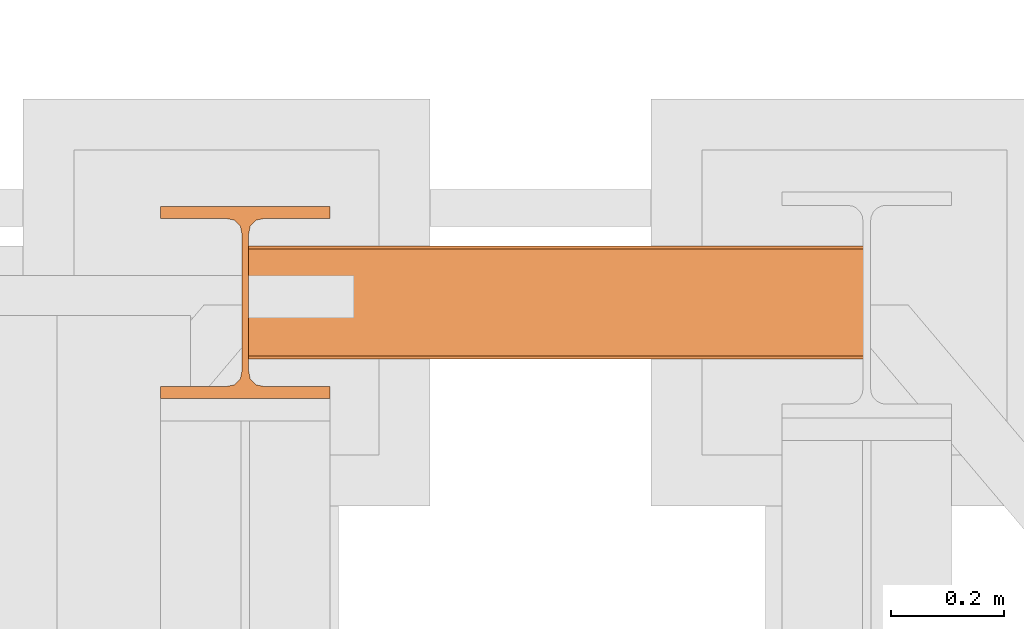
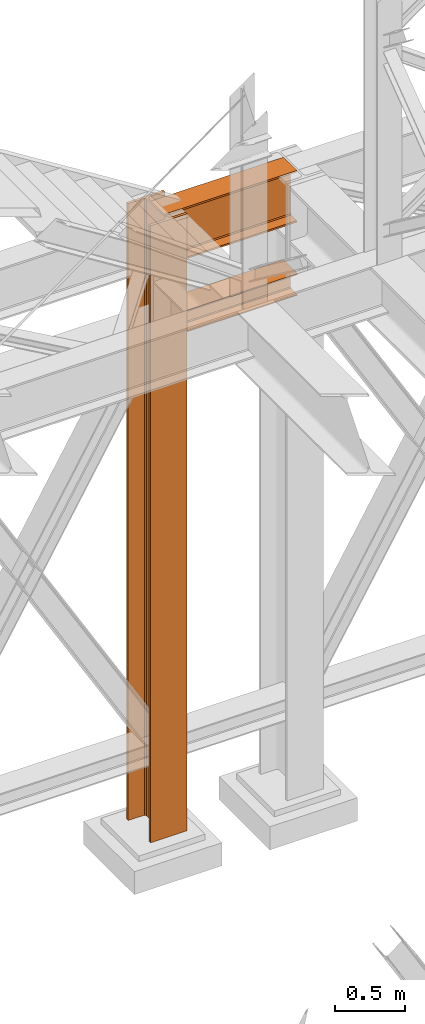
# One storey, part 136 of 208: 3 proxies.
"""IFC2X3 building model written with IfcOpenShell, lengths in millimetres."""

from ifc_helpers import new_model, entity, si_unit, converted_unit, frame, origin, origin_with_axes, place, context, subcontext, project, spatial, faceted_brep, material, element, save


model = new_model("IFC2X3")

# Units and contexts
model_context = context("Model", 3, precision=1e-05, world=origin())
plan_context = context("Plan", 3, precision=1e-05, world=origin())
body_context = subcontext(model_context, "Body", "Model", "MODEL_VIEW")
ifc_project = project(units=[si_unit("LENGTHUNIT", "METRE", prefix="MILLI"), converted_unit("PLANEANGLEUNIT", "DEGREE", entity("IfcPlaneAngleMeasure", 0.0174532925199433), si_unit("PLANEANGLEUNIT", "RADIAN"), dimensions=[0, 0, 0, 0, 0, 0, 0]), si_unit("AREAUNIT", "SQUARE_METRE"), si_unit("VOLUMEUNIT", "CUBIC_METRE")], contexts=[model_context, plan_context])

# Building, storey
building_placement = place(None, origin())
building = spatial("IfcBuilding", under=ifc_project, at=building_placement, CompositionType="COMPLEX")
storey_placement = place(building_placement, origin_with_axes())
storey = spatial("IfcBuildingStorey", under=building, at=storey_placement, Name="Geschoss", CompositionType="ELEMENT")

# Proxies
proxy_1_placement = place(storey_placement, frame((-1100.745031419179, -12557.57439978601, 4834.989987483023), z_axis=(0.0, 0.0, 1.0), x_axis=(1.0, 0.0, 0.0)))
element("IfcBuildingElementProxy", 1, at=proxy_1_placement, inside=storey, context=body_context, shape_type="Brep", body=[
    faceted_brep([(1088.009999895696, 0.01000000000021828, 450.0100178813937), (1088.009999895696, 190.0100125169756, 450.0100178813937), (1088.009999895696, 190.0100125169756, 435.4100240564349), (1088.009999895696, 120.7100073045494, 435.4100091552737), (1088.009999895696, 109.841562265754, 433.2347078418734), (1088.009999895696, 101.8853126263621, 425.2784563398363), (1088.009999895696, 99.71000619068764, 414.4100113010409), (1088.009999895696, 99.71000619068764, 35.60999167919181), (1088.009999895696, 101.8853126263621, 24.74154664039634), (1088.009999895696, 109.841562265754, 16.78529513835929), (1088.009999895696, 120.7100073045494, 14.60999382495902), (1088.009999895696, 190.0100125169756, 14.60999382495902), (1088.009999895696, 190.0100125169756, 0.01000000000021828), (1088.009999895696, 0.01000000000021828, 0.01000000000021828), (1088.009999895696, 0.01000000000021828, 14.60999382495902), (1088.009999895696, 69.3100052124264, 14.60999382495902), (1088.009999895696, 80.17845025122188, 16.78529513835929), (1088.009999895696, 88.13469989061377, 24.74154664039634), (1088.009999895696, 90.3100063262882, 35.60999167919181), (1088.009999895696, 90.3100063262882, 414.4100113010409), (1088.009999895696, 88.13469989061377, 425.2784563398363), (1088.009999895696, 80.17845025122188, 433.2347078418734), (1088.009999895696, 69.3100052124264, 435.4100091552737), (1088.009999895696, 0.01000000000021828, 435.4100240564349), (1088.009999895696, 190.0100125169756, 450.0100178813937), (1088.009999895696, 0.01000000000021828, 450.0100178813937), (0.009999999999990905, 0.01000000000021828, 450.0100178813937), (0.009999999999990905, 190.0100125169756, 450.0100178813937), (1088.009999895696, 190.0100125169756, 435.4100240564349), (1088.009999895696, 190.0100125169756, 450.0100178813937), (0.009999999999990905, 190.0100125169756, 450.0100178813937), (0.009999999999990905, 190.0100125169756, 435.4100240564349), (1088.009999895696, 120.7100073045494, 435.4100091552737), (1088.009999895696, 190.0100125169756, 435.4100240564349), (0.009999999999990905, 190.0100125169756, 435.4100240564349), (0.009999999999990905, 120.7100073045494, 435.4100091552737), (1088.009999895696, 109.841562265754, 433.2347078418734), (1088.009999895696, 120.7100073045494, 435.4100091552737), (0.009999999999990905, 120.7100073045494, 435.4100091552737), (0.009999999999990905, 109.841562265754, 433.2347078418734), (1088.009999895696, 101.8853126263621, 425.2784563398363), (1088.009999895696, 109.841562265754, 433.2347078418734), (0.009999999999990905, 109.841562265754, 433.2347078418734), (0.009999999999990905, 101.8853126263621, 425.2784563398363), (1088.009999895696, 99.71000619068764, 414.4100113010409), (1088.009999895696, 101.8853126263621, 425.2784563398363), (0.009999999999990905, 101.8853126263621, 425.2784563398363), (0.009999999999990905, 99.71000619068764, 414.4100113010409), (1088.009999895696, 99.71000619068764, 35.60999167919181), (1088.009999895696, 99.71000619068764, 414.4100113010409), (0.009999999999990905, 99.71000619068764, 414.4100113010409), (0.009999999999990905, 99.71000619068764, 35.60999167919181), (1088.009999895696, 101.8853126263621, 24.74154664039634), (1088.009999895696, 99.71000619068764, 35.60999167919181), (0.009999999999990905, 99.71000619068764, 35.60999167919181), (0.009999999999990905, 101.8853126263621, 24.74154664039634), (1088.009999895696, 109.841562265754, 16.78529513835929), (1088.009999895696, 101.8853126263621, 24.74154664039634), (0.009999999999990905, 101.8853126263621, 24.74154664039634), (0.009999999999990905, 109.841562265754, 16.78529513835929), (1088.009999895696, 120.7100073045494, 14.60999382495902), (1088.009999895696, 109.841562265754, 16.78529513835929), (0.009999999999990905, 109.841562265754, 16.78529513835929), (0.009999999999990905, 120.7100073045494, 14.60999382495902), (1088.009999895696, 190.0100125169756, 14.60999382495902), (1088.009999895696, 120.7100073045494, 14.60999382495902), (0.009999999999990905, 120.7100073045494, 14.60999382495902), (0.009999999999990905, 190.0100125169756, 14.60999382495902), (1088.009999895696, 190.0100125169756, 0.01000000000021828), (1088.009999895696, 190.0100125169756, 14.60999382495902), (0.009999999999990905, 190.0100125169756, 14.60999382495902), (0.009999999999990905, 190.0100125169756, 0.01000000000021828), (1088.009999895696, 0.01000000000021828, 0.01000000000021828), (1088.009999895696, 190.0100125169756, 0.01000000000021828), (0.009999999999990905, 190.0100125169756, 0.01000000000021828), (0.009999999999990905, 0.01000000000021828, 0.01000000000021828), (1088.009999895696, 0.01000000000021828, 14.60999382495902), (1088.009999895696, 0.01000000000021828, 0.01000000000021828), (0.009999999999990905, 0.01000000000021828, 0.01000000000021828), (0.009999999999990905, 0.01000000000021828, 14.60999382495902), (1088.009999895696, 69.3100052124264, 14.60999382495902), (1088.009999895696, 0.01000000000021828, 14.60999382495902), (0.009999999999990905, 0.01000000000021828, 14.60999382495902), (0.009999999999990905, 69.3100052124264, 14.60999382495902), (1088.009999895696, 80.17845025122188, 16.78529513835929), (1088.009999895696, 69.3100052124264, 14.60999382495902), (0.009999999999990905, 69.3100052124264, 14.60999382495902), (0.009999999999990905, 80.17845025122188, 16.78529513835929), (1088.009999895696, 88.13469989061377, 24.74154664039634), (1088.009999895696, 80.17845025122188, 16.78529513835929), (0.009999999999990905, 80.17845025122188, 16.78529513835929), (0.009999999999990905, 88.13469989061377, 24.74154664039634), (1088.009999895696, 90.3100063262882, 35.60999167919181), (1088.009999895696, 88.13469989061377, 24.74154664039634), (0.009999999999990905, 88.13469989061377, 24.74154664039634), (0.009999999999990905, 90.3100063262882, 35.60999167919181), (1088.009999895696, 90.3100063262882, 414.4100113010409), (1088.009999895696, 90.3100063262882, 35.60999167919181), (0.009999999999990905, 90.3100063262882, 35.60999167919181), (0.009999999999990905, 90.3100063262882, 414.4100113010409), (1088.009999895696, 88.13469989061377, 425.2784563398363), (1088.009999895696, 90.3100063262882, 414.4100113010409), (0.009999999999990905, 90.3100063262882, 414.4100113010409), (0.009999999999990905, 88.13469989061377, 425.2784563398363), (1088.009999895696, 80.17845025122188, 433.2347078418734), (1088.009999895696, 88.13469989061377, 425.2784563398363), (0.009999999999990905, 88.13469989061377, 425.2784563398363), (0.009999999999990905, 80.17845025122188, 433.2347078418734), (1088.009999895696, 69.3100052124264, 435.4100091552737), (1088.009999895696, 80.17845025122188, 433.2347078418734), (0.009999999999990905, 80.17845025122188, 433.2347078418734), (0.009999999999990905, 69.3100052124264, 435.4100091552737), (1088.009999895696, 0.01000000000021828, 435.4100240564349), (1088.009999895696, 69.3100052124264, 435.4100091552737), (0.009999999999990905, 69.3100052124264, 435.4100091552737), (0.009999999999990905, 0.01000000000021828, 435.4100240564349), (1088.009999895696, 0.01000000000021828, 450.0100178813937), (1088.009999895696, 0.01000000000021828, 435.4100240564349), (0.009999999999990905, 0.01000000000021828, 435.4100240564349), (0.009999999999990905, 0.01000000000021828, 450.0100178813937), (0.009999999999990905, 0.01000000000021828, 450.0100178813937), (0.009999999999990905, 0.01000000000021828, 435.4100240564349), (0.009999999999990905, 69.3100052124264, 435.4100091552737), (0.009999999999990905, 80.17845025122188, 433.2347078418734), (0.009999999999990905, 88.13469989061377, 425.2784563398363), (0.009999999999990905, 90.3100063262882, 414.4100113010409), (0.009999999999990905, 90.3100063262882, 35.60999167919181), (0.009999999999990905, 88.13469989061377, 24.74154664039634), (0.009999999999990905, 80.17845025122188, 16.78529513835929), (0.009999999999990905, 69.3100052124264, 14.60999382495902), (0.009999999999990905, 0.01000000000021828, 14.60999382495902), (0.009999999999990905, 0.01000000000021828, 0.01000000000021828), (0.009999999999990905, 190.0100125169756, 0.01000000000021828), (0.009999999999990905, 190.0100125169756, 14.60999382495902), (0.009999999999990905, 120.7100073045494, 14.60999382495902), (0.009999999999990905, 109.841562265754, 16.78529513835929), (0.009999999999990905, 101.8853126263621, 24.74154664039634), (0.009999999999990905, 99.71000619068764, 35.60999167919181), (0.009999999999990905, 99.71000619068764, 414.4100113010409), (0.009999999999990905, 101.8853126263621, 425.2784563398363), (0.009999999999990905, 109.841562265754, 433.2347078418734), (0.009999999999990905, 120.7100073045494, 435.4100091552737), (0.009999999999990905, 190.0100125169756, 435.4100240564349), (0.009999999999990905, 190.0100125169756, 450.0100178813937)], [[[0, 1, 2, 3, 4, 5, 6, 7, 8, 9, 10, 11, 12, 13, 14, 15, 16, 17, 18, 19, 20, 21, 22, 23]], [[24, 25, 26, 27]], [[28, 29, 30, 31]], [[32, 33, 34, 35]], [[36, 37, 38, 39]], [[40, 41, 42, 43]], [[44, 45, 46, 47]], [[48, 49, 50, 51]], [[52, 53, 54, 55]], [[56, 57, 58, 59]], [[60, 61, 62, 63]], [[64, 65, 66, 67]], [[68, 69, 70, 71]], [[72, 73, 74, 75]], [[76, 77, 78, 79]], [[80, 81, 82, 83]], [[84, 85, 86, 87]], [[88, 89, 90, 91]], [[92, 93, 94, 95]], [[96, 97, 98, 99]], [[100, 101, 102, 103]], [[104, 105, 106, 107]], [[108, 109, 110, 111]], [[112, 113, 114, 115]], [[116, 117, 118, 119]], [[120, 121, 122, 123, 124, 125, 126, 127, 128, 129, 130, 131, 132, 133, 134, 135, 136, 137, 138, 139, 140, 141, 142, 143]]], orient=[[False], [False], [False], [False], [False], [False], [False], [False], [False], [False], [False], [False], [False], [False], [False], [False], [False], [False], [False], [False], [False], [False], [False], [False], [False], [False]]),
])
ifc_material = material(Name="35/80cm")
proxy_2_placement = place(storey_placement, frame((-1256.745037431798, -12632.57439531566, -65.01000000000022), z_axis=(0.0, 0.0, 1.0), x_axis=(1.0, 0.0, 0.0)))
element("IfcBuildingElementProxy", 2, at=proxy_2_placement, inside=storey, material=ifc_material, context=body_context, shape_type="Brep", body=[
    faceted_brep([(300.010011920929, 0.01000000000021828, 0.01000000000027512), (300.010011920929, 21.51000631809256, 0.01000000000027512), (183.0100057816505, 21.51000631809256, 0.01000000000027512), (169.0362909978628, 24.30682016372703, 0.01000000000027512), (158.8068282401562, 34.53628850936912, 0.01000000000027512), (156.0100060126185, 48.51000143051169, 0.01000000000027512), (156.0100060126185, 291.5099946951868, 0.01000000000027512), (158.8068282401562, 305.48371506691, 0.01000000000027512), (169.0362909978628, 315.7131685113909, 0.01000000000027512), (183.0100057816505, 318.5099972581866, 0.01000000000027512), (300.010011920929, 318.5099972581866, 0.01000000000027512), (300.010011920929, 340.0100035762789, 0.01000000000027512), (0.009999999999990905, 340.0100035762789, 0.01000000000027512), (0.009999999999990905, 318.5099972581866, 0.01000000000027512), (117.0100061392784, 318.5099972581866, 0.01000000000027512), (130.9837209230661, 315.7131685113909, 0.01000000000027512), (141.2131836807728, 305.48371506691, 0.01000000000027512), (144.0100059083104, 291.5099946951868, 0.01000000000027512), (144.0100059083104, 48.51000143051169, 0.01000000000027512), (141.2131836807728, 34.53628850936912, 0.01000000000027512), (130.9837209230661, 24.30682016372703, 0.01000000000027512), (117.0100061392784, 21.51000631809256, 0.01000000000027512), (0.009999999999990905, 21.51000631809256, 0.01000000000027512), (0.009999999999990905, 0.01000000000021828, 0.01000000000027512), (300.010011920929, 21.51000631809256, 5350.010005364416), (300.010011920929, 0.01000000000021828, 5350.010005364416), (0.009999999999990905, 0.01000000000021828, 5350.010005364416), (0.009999999999990905, 21.51000631809256, 5350.010005364416), (117.0100061392784, 21.51000631809256, 5350.010005364416), (130.9837209230661, 24.30682016372703, 5350.010005364416), (141.2131836807728, 34.53628850936912, 5350.010005364416), (144.0100059083104, 48.51000143051169, 5350.010005364416), (144.0100059083104, 291.5099946951868, 5350.010005364416), (141.2131836807728, 305.48371506691, 5350.010005364416), (130.9837209230661, 315.7131685113909, 5350.010005364416), (117.0100061392784, 318.5099972581866, 5350.010005364416), (0.009999999999990905, 318.5099972581866, 5350.010005364416), (0.009999999999990905, 340.0100035762789, 5350.010005364416), (300.010011920929, 340.0100035762789, 5350.010005364416), (300.010011920929, 318.5099972581866, 5350.010005364416), (183.0100057816505, 318.5099972581866, 5350.010005364416), (169.0362909978628, 315.7131685113909, 5350.010005364416), (158.8068282401562, 305.48371506691, 5350.010005364416), (156.0100060126185, 291.5099946951868, 5350.010005364416), (156.0100060126185, 48.51000143051169, 5350.010005364416), (158.8068282401562, 34.53628850936912, 5350.010005364416), (169.0362909978628, 24.30682016372703, 5350.010005364416), (183.0100057816505, 21.51000631809256, 5350.010005364416), (300.010011920929, 21.51000631809256, 0.01000000000027512), (300.010011920929, 0.01000000000021828, 0.01000000000027512), (300.010011920929, 0.01000000000021828, 5350.010005364416), (300.010011920929, 21.51000631809256, 5350.010005364416), (183.0100057816505, 21.51000631809256, 0.01000000000027512), (300.010011920929, 21.51000631809256, 0.01000000000027512), (300.010011920929, 21.51000631809256, 5350.010005364416), (183.0100057816505, 21.51000631809256, 5350.010005364416), (169.0362909978628, 24.30682016372703, 0.01000000000027512), (183.0100057816505, 21.51000631809256, 0.01000000000027512), (183.0100057816505, 21.51000631809256, 5350.010005364416), (169.0362909978628, 24.30682016372703, 5350.010005364416), (158.8068282401562, 34.53628850936912, 0.01000000000027512), (169.0362909978628, 24.30682016372703, 0.01000000000027512), (169.0362909978628, 24.30682016372703, 5350.010005364416), (158.8068282401562, 34.53628850936912, 5350.010005364416), (156.0100060126185, 48.51000143051169, 0.01000000000027512), (158.8068282401562, 34.53628850936912, 0.01000000000027512), (158.8068282401562, 34.53628850936912, 5350.010005364416), (156.0100060126185, 48.51000143051169, 5350.010005364416), (156.0100060126185, 291.5099946951868, 0.01000000000027512), (156.0100060126185, 48.51000143051169, 0.01000000000027512), (156.0100060126185, 48.51000143051169, 5350.010005364416), (156.0100060126185, 291.5099946951868, 5350.010005364416), (158.8068282401562, 305.48371506691, 0.01000000000027512), (156.0100060126185, 291.5099946951868, 0.01000000000027512), (156.0100060126185, 291.5099946951868, 5350.010005364416), (158.8068282401562, 305.48371506691, 5350.010005364416), (169.0362909978628, 315.7131685113909, 0.01000000000027512), (158.8068282401562, 305.48371506691, 0.01000000000027512), (158.8068282401562, 305.48371506691, 5350.010005364416), (169.0362909978628, 315.7131685113909, 5350.010005364416), (183.0100057816505, 318.5099972581866, 0.01000000000027512), (169.0362909978628, 315.7131685113909, 0.01000000000027512), (169.0362909978628, 315.7131685113909, 5350.010005364416), (183.0100057816505, 318.5099972581866, 5350.010005364416), (300.010011920929, 318.5099972581866, 0.01000000000027512), (183.0100057816505, 318.5099972581866, 0.01000000000027512), (183.0100057816505, 318.5099972581866, 5350.010005364416), (300.010011920929, 318.5099972581866, 5350.010005364416), (300.010011920929, 340.0100035762789, 0.01000000000027512), (300.010011920929, 318.5099972581866, 0.01000000000027512), (300.010011920929, 318.5099972581866, 5350.010005364416), (300.010011920929, 340.0100035762789, 5350.010005364416), (0.009999999999990905, 340.0100035762789, 0.01000000000027512), (300.010011920929, 340.0100035762789, 0.01000000000027512), (300.010011920929, 340.0100035762789, 5350.010005364416), (0.009999999999990905, 340.0100035762789, 5350.010005364416), (0.009999999999990905, 318.5099972581866, 0.01000000000027512), (0.009999999999990905, 340.0100035762789, 0.01000000000027512), (0.009999999999990905, 340.0100035762789, 5350.010005364416), (0.009999999999990905, 318.5099972581866, 5350.010005364416), (117.0100061392784, 318.5099972581866, 0.01000000000027512), (0.009999999999990905, 318.5099972581866, 0.01000000000027512), (0.009999999999990905, 318.5099972581866, 5350.010005364416), (117.0100061392784, 318.5099972581866, 5350.010005364416), (130.9837209230661, 315.7131685113909, 0.01000000000027512), (117.0100061392784, 318.5099972581866, 0.01000000000027512), (117.0100061392784, 318.5099972581866, 5350.010005364416), (130.9837209230661, 315.7131685113909, 5350.010005364416), (141.2131836807728, 305.48371506691, 0.01000000000027512), (130.9837209230661, 315.7131685113909, 0.01000000000027512), (130.9837209230661, 315.7131685113909, 5350.010005364416), (141.2131836807728, 305.48371506691, 5350.010005364416), (144.0100059083104, 291.5099946951868, 0.01000000000027512), (141.2131836807728, 305.48371506691, 0.01000000000027512), (141.2131836807728, 305.48371506691, 5350.010005364416), (144.0100059083104, 291.5099946951868, 5350.010005364416), (144.0100059083104, 48.51000143051169, 0.01000000000027512), (144.0100059083104, 291.5099946951868, 0.01000000000027512), (144.0100059083104, 291.5099946951868, 5350.010005364416), (144.0100059083104, 48.51000143051169, 5350.010005364416), (141.2131836807728, 34.53628850936912, 0.01000000000027512), (144.0100059083104, 48.51000143051169, 0.01000000000027512), (144.0100059083104, 48.51000143051169, 5350.010005364416), (141.2131836807728, 34.53628850936912, 5350.010005364416), (130.9837209230661, 24.30682016372703, 0.01000000000027512), (141.2131836807728, 34.53628850936912, 0.01000000000027512), (141.2131836807728, 34.53628850936912, 5350.010005364416), (130.9837209230661, 24.30682016372703, 5350.010005364416), (117.0100061392784, 21.51000631809256, 0.01000000000027512), (130.9837209230661, 24.30682016372703, 0.01000000000027512), (130.9837209230661, 24.30682016372703, 5350.010005364416), (117.0100061392784, 21.51000631809256, 5350.010005364416), (0.009999999999990905, 21.51000631809256, 0.01000000000027512), (117.0100061392784, 21.51000631809256, 0.01000000000027512), (117.0100061392784, 21.51000631809256, 5350.010005364416), (0.009999999999990905, 21.51000631809256, 5350.010005364416), (0.009999999999990905, 0.01000000000021828, 0.01000000000027512), (0.009999999999990905, 21.51000631809256, 0.01000000000027512), (0.009999999999990905, 21.51000631809256, 5350.010005364416), (0.009999999999990905, 0.01000000000021828, 5350.010005364416), (300.010011920929, 0.01000000000021828, 0.01000000000027512), (0.009999999999990905, 0.01000000000021828, 0.01000000000027512), (0.009999999999990905, 0.01000000000021828, 5350.010005364416), (300.010011920929, 0.01000000000021828, 5350.010005364416)], [[[0, 1, 2, 3, 4, 5, 6, 7, 8, 9, 10, 11, 12, 13, 14, 15, 16, 17, 18, 19, 20, 21, 22, 23]], [[24, 25, 26, 27, 28, 29, 30, 31, 32, 33, 34, 35, 36, 37, 38, 39, 40, 41, 42, 43, 44, 45, 46, 47]], [[48, 49, 50, 51]], [[52, 53, 54, 55]], [[56, 57, 58, 59]], [[60, 61, 62, 63]], [[64, 65, 66, 67]], [[68, 69, 70, 71]], [[72, 73, 74, 75]], [[76, 77, 78, 79]], [[80, 81, 82, 83]], [[84, 85, 86, 87]], [[88, 89, 90, 91]], [[92, 93, 94, 95]], [[96, 97, 98, 99]], [[100, 101, 102, 103]], [[104, 105, 106, 107]], [[108, 109, 110, 111]], [[112, 113, 114, 115]], [[116, 117, 118, 119]], [[120, 121, 122, 123]], [[124, 125, 126, 127]], [[128, 129, 130, 131]], [[132, 133, 134, 135]], [[136, 137, 138, 139]], [[140, 141, 142, 143]]], orient=[[False], [False], [False], [False], [False], [False], [False], [False], [False], [False], [False], [False], [False], [False], [False], [False], [False], [False], [False], [False], [False], [False], [False], [False], [False], [False]]),
])
proxy_3_placement = place(storey_placement, frame((-1100.745031419175, -12562.57439501763, 4202.989992847441), z_axis=(0.0, 0.0, 1.0), x_axis=(1.0, 0.0, 0.0)))
element("IfcBuildingElementProxy", 3, at=proxy_3_placement, inside=storey, context=body_context, shape_type="Brep", body=[
    faceted_brep([(1088.009999895692, 0.01000000000021828, 190.0100125169756), (1088.009999895692, 200.0100029802325, 190.0100125169756), (1088.009999895692, 200.0100029802325, 180.0100146031382), (1088.009999895692, 121.2600035762789, 180.0100071525576), (1088.009999895692, 111.9441915473344, 178.1454621052744), (1088.009999895692, 105.1245498640838, 171.3258190250399), (1088.009999895692, 103.2600015571716, 162.010007927418), (1088.009999895692, 103.2600015571716, 28.00999713897727), (1088.009999895692, 105.1245498640838, 18.69418604135535), (1088.009999895692, 111.9441915473344, 11.87454296112082), (1088.009999895692, 121.2600035762789, 10.00999791383765), (1088.009999895692, 200.0100029802325, 10.00999791383765), (1088.009999895692, 200.0100029802325, 0.01000000000021828), (1088.009999895692, 0.01000000000021828, 0.01000000000021828), (1088.009999895692, 0.01000000000021828, 10.00999791383765), (1088.009999895692, 78.75999940395377, 10.00999791383765), (1088.009999895692, 88.07581143289826, 11.87454296112082), (1088.009999895692, 94.89545311614893, 18.69418604135535), (1088.009999895692, 96.76000142306111, 28.00999713897727), (1088.009999895692, 96.76000142306111, 162.010007927418), (1088.009999895692, 94.89545311614893, 171.3258190250399), (1088.009999895692, 88.07581143289826, 178.1454621052744), (1088.009999895692, 78.75999940395377, 180.0100071525576), (1088.009999895692, 0.01000000000021828, 180.0100146031382), (1088.009999895692, 200.0100029802325, 190.0100125169756), (1088.009999895692, 0.01000000000021828, 190.0100125169756), (0.009999999999990905, 0.01000000000021828, 190.0100125169756), (0.009999999999990905, 200.0100029802325, 190.0100125169756), (1088.009999895692, 200.0100029802325, 180.0100146031382), (1088.009999895692, 200.0100029802325, 190.0100125169756), (0.009999999999990905, 200.0100029802325, 190.0100125169756), (0.009999999999990905, 200.0100029802325, 180.0100146031382), (1088.009999895692, 121.2600035762789, 180.0100071525576), (1088.009999895692, 200.0100029802325, 180.0100146031382), (0.009999999999990905, 200.0100029802325, 180.0100146031382), (0.009999999999990905, 121.2600035762789, 180.0100071525576), (1088.009999895692, 111.9441915473344, 178.1454621052744), (1088.009999895692, 121.2600035762789, 180.0100071525576), (0.009999999999990905, 121.2600035762789, 180.0100071525576), (0.009999999999990905, 111.9441915473344, 178.1454621052744), (1088.009999895692, 105.1245498640838, 171.3258190250399), (1088.009999895692, 111.9441915473344, 178.1454621052744), (0.009999999999990905, 111.9441915473344, 178.1454621052744), (0.009999999999990905, 105.1245498640838, 171.3258190250399), (1088.009999895692, 103.2600015571716, 162.010007927418), (1088.009999895692, 105.1245498640838, 171.3258190250399), (0.009999999999990905, 105.1245498640838, 171.3258190250399), (0.009999999999990905, 103.2600015571716, 162.010007927418), (1088.009999895692, 103.2600015571716, 28.00999713897727), (1088.009999895692, 103.2600015571716, 162.010007927418), (0.009999999999990905, 103.2600015571716, 162.010007927418), (0.009999999999990905, 103.2600015571716, 28.00999713897727), (1088.009999895692, 105.1245498640838, 18.69418604135535), (1088.009999895692, 103.2600015571716, 28.00999713897727), (0.009999999999990905, 103.2600015571716, 28.00999713897727), (0.009999999999990905, 105.1245498640838, 18.69418604135535), (1088.009999895692, 111.9441915473344, 11.87454296112082), (1088.009999895692, 105.1245498640838, 18.69418604135535), (0.009999999999990905, 105.1245498640838, 18.69418604135535), (0.009999999999990905, 111.9441915473344, 11.87454296112082), (1088.009999895692, 121.2600035762789, 10.00999791383765), (1088.009999895692, 111.9441915473344, 11.87454296112082), (0.009999999999990905, 111.9441915473344, 11.87454296112082), (0.009999999999990905, 121.2600035762789, 10.00999791383765), (1088.009999895692, 200.0100029802325, 10.00999791383765), (1088.009999895692, 121.2600035762789, 10.00999791383765), (0.009999999999990905, 121.2600035762789, 10.00999791383765), (0.009999999999990905, 200.0100029802325, 10.00999791383765), (1088.009999895692, 200.0100029802325, 0.01000000000021828), (1088.009999895692, 200.0100029802325, 10.00999791383765), (0.009999999999990905, 200.0100029802325, 10.00999791383765), (0.009999999999990905, 200.0100029802325, 0.01000000000021828), (1088.009999895692, 0.01000000000021828, 0.01000000000021828), (1088.009999895692, 200.0100029802325, 0.01000000000021828), (0.009999999999990905, 200.0100029802325, 0.01000000000021828), (0.009999999999990905, 0.01000000000021828, 0.01000000000021828), (1088.009999895692, 0.01000000000021828, 10.00999791383765), (1088.009999895692, 0.01000000000021828, 0.01000000000021828), (0.009999999999990905, 0.01000000000021828, 0.01000000000021828), (0.009999999999990905, 0.01000000000021828, 10.00999791383765), (1088.009999895692, 78.75999940395377, 10.00999791383765), (1088.009999895692, 0.01000000000021828, 10.00999791383765), (0.009999999999990905, 0.01000000000021828, 10.00999791383765), (0.009999999999990905, 78.75999940395377, 10.00999791383765), (1088.009999895692, 88.07581143289826, 11.87454296112082), (1088.009999895692, 78.75999940395377, 10.00999791383765), (0.009999999999990905, 78.75999940395377, 10.00999791383765), (0.009999999999990905, 88.07581143289826, 11.87454296112082), (1088.009999895692, 94.89545311614893, 18.69418604135535), (1088.009999895692, 88.07581143289826, 11.87454296112082), (0.009999999999990905, 88.07581143289826, 11.87454296112082), (0.009999999999990905, 94.89545311614893, 18.69418604135535), (1088.009999895692, 96.76000142306111, 28.00999713897727), (1088.009999895692, 94.89545311614893, 18.69418604135535), (0.009999999999990905, 94.89545311614893, 18.69418604135535), (0.009999999999990905, 96.76000142306111, 28.00999713897727), (1088.009999895692, 96.76000142306111, 162.010007927418), (1088.009999895692, 96.76000142306111, 28.00999713897727), (0.009999999999990905, 96.76000142306111, 28.00999713897727), (0.009999999999990905, 96.76000142306111, 162.010007927418), (1088.009999895692, 94.89545311614893, 171.3258190250399), (1088.009999895692, 96.76000142306111, 162.010007927418), (0.009999999999990905, 96.76000142306111, 162.010007927418), (0.009999999999990905, 94.89545311614893, 171.3258190250399), (1088.009999895692, 88.07581143289826, 178.1454621052744), (1088.009999895692, 94.89545311614893, 171.3258190250399), (0.009999999999990905, 94.89545311614893, 171.3258190250399), (0.009999999999990905, 88.07581143289826, 178.1454621052744), (1088.009999895692, 78.75999940395377, 180.0100071525576), (1088.009999895692, 88.07581143289826, 178.1454621052744), (0.009999999999990905, 88.07581143289826, 178.1454621052744), (0.009999999999990905, 78.75999940395377, 180.0100071525576), (1088.009999895692, 0.01000000000021828, 180.0100146031382), (1088.009999895692, 78.75999940395377, 180.0100071525576), (0.009999999999990905, 78.75999940395377, 180.0100071525576), (0.009999999999990905, 0.01000000000021828, 180.0100146031382), (1088.009999895692, 0.01000000000021828, 190.0100125169756), (1088.009999895692, 0.01000000000021828, 180.0100146031382), (0.009999999999990905, 0.01000000000021828, 180.0100146031382), (0.009999999999990905, 0.01000000000021828, 190.0100125169756), (0.009999999999990905, 0.01000000000021828, 190.0100125169756), (0.009999999999990905, 0.01000000000021828, 180.0100146031382), (0.009999999999990905, 78.75999940395377, 180.0100071525576), (0.009999999999990905, 88.07581143289826, 178.1454621052744), (0.009999999999990905, 94.89545311614893, 171.3258190250399), (0.009999999999990905, 96.76000142306111, 162.010007927418), (0.009999999999990905, 96.76000142306111, 28.00999713897727), (0.009999999999990905, 94.89545311614893, 18.69418604135535), (0.009999999999990905, 88.07581143289826, 11.87454296112082), (0.009999999999990905, 78.75999940395377, 10.00999791383765), (0.009999999999990905, 0.01000000000021828, 10.00999791383765), (0.009999999999990905, 0.01000000000021828, 0.01000000000021828), (0.009999999999990905, 200.0100029802325, 0.01000000000021828), (0.009999999999990905, 200.0100029802325, 10.00999791383765), (0.009999999999990905, 121.2600035762789, 10.00999791383765), (0.009999999999990905, 111.9441915473344, 11.87454296112082), (0.009999999999990905, 105.1245498640838, 18.69418604135535), (0.009999999999990905, 103.2600015571716, 28.00999713897727), (0.009999999999990905, 103.2600015571716, 162.010007927418), (0.009999999999990905, 105.1245498640838, 171.3258190250399), (0.009999999999990905, 111.9441915473344, 178.1454621052744), (0.009999999999990905, 121.2600035762789, 180.0100071525576), (0.009999999999990905, 200.0100029802325, 180.0100146031382), (0.009999999999990905, 200.0100029802325, 190.0100125169756)], [[[0, 1, 2, 3, 4, 5, 6, 7, 8, 9, 10, 11, 12, 13, 14, 15, 16, 17, 18, 19, 20, 21, 22, 23]], [[24, 25, 26, 27]], [[28, 29, 30, 31]], [[32, 33, 34, 35]], [[36, 37, 38, 39]], [[40, 41, 42, 43]], [[44, 45, 46, 47]], [[48, 49, 50, 51]], [[52, 53, 54, 55]], [[56, 57, 58, 59]], [[60, 61, 62, 63]], [[64, 65, 66, 67]], [[68, 69, 70, 71]], [[72, 73, 74, 75]], [[76, 77, 78, 79]], [[80, 81, 82, 83]], [[84, 85, 86, 87]], [[88, 89, 90, 91]], [[92, 93, 94, 95]], [[96, 97, 98, 99]], [[100, 101, 102, 103]], [[104, 105, 106, 107]], [[108, 109, 110, 111]], [[112, 113, 114, 115]], [[116, 117, 118, 119]], [[120, 121, 122, 123, 124, 125, 126, 127, 128, 129, 130, 131, 132, 133, 134, 135, 136, 137, 138, 139, 140, 141, 142, 143]]], orient=[[False], [False], [False], [False], [False], [False], [False], [False], [False], [False], [False], [False], [False], [False], [False], [False], [False], [False], [False], [False], [False], [False], [False], [False], [False], [False]]),
])

save(model, "model.ifc")
